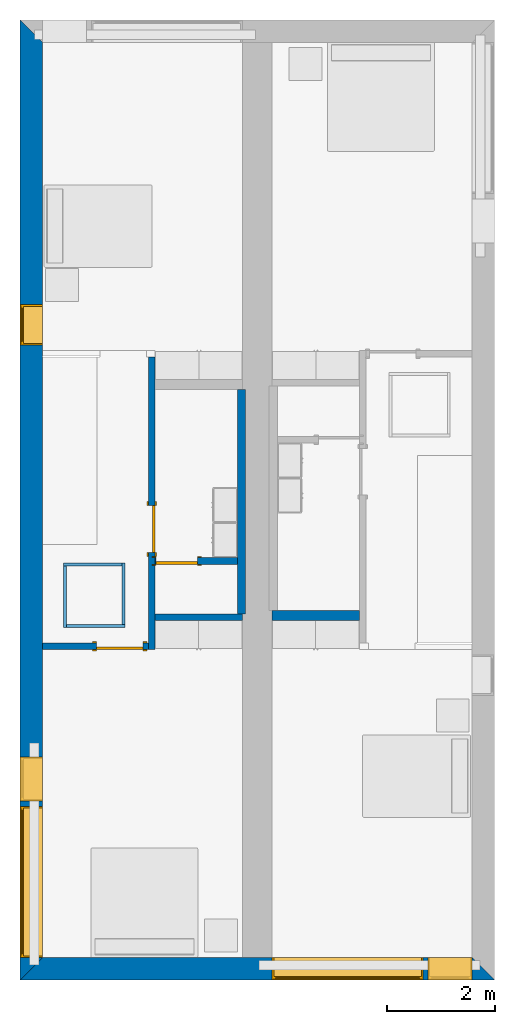
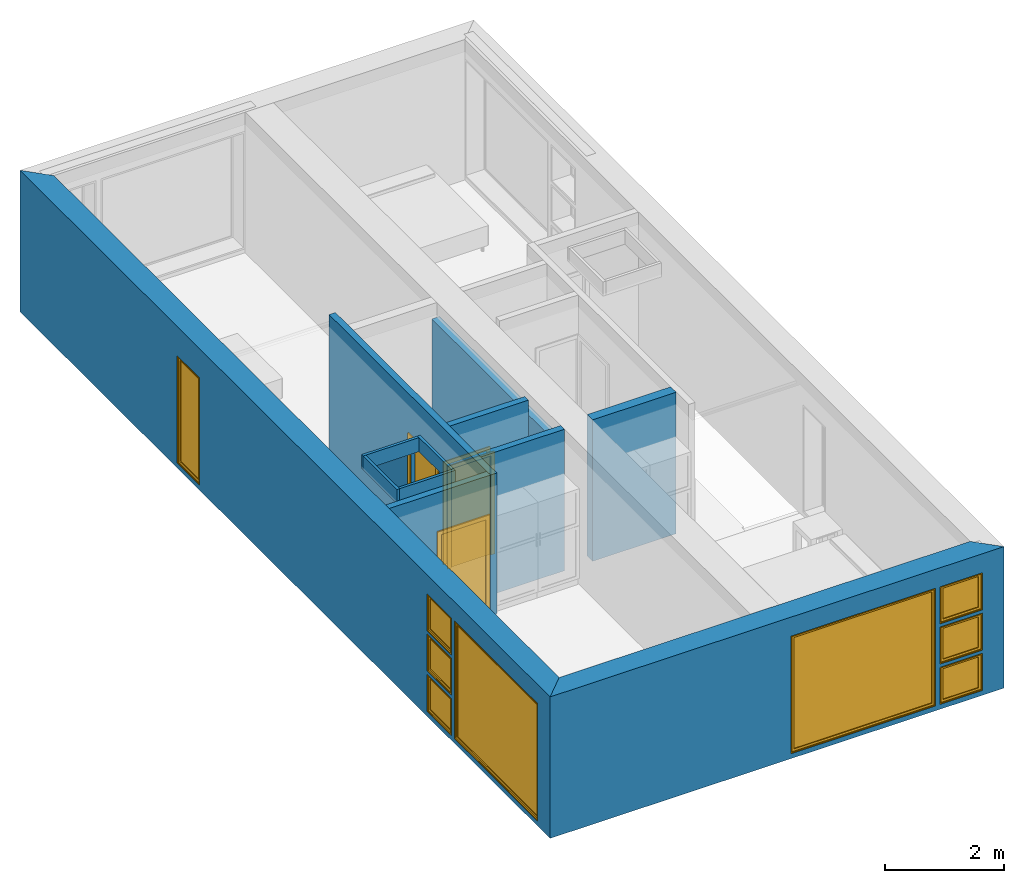
# One storey, part 2 of 12: 12 walls, 9 windows, 3 doors, 12 openings.
"""IFC2X3 building model written with IfcOpenShell, lengths in metres."""

import ifcopenshell
import ifcopenshell.guid

model = None  # the IFC model being written
_history = None  # IfcOwnerHistory: only IFC2X3 demands one
_inside = {}  # id of a spatial element -> (the spatial element, [elements in it])
_under = {}  # id of a project, library or spatial element -> (it, [spatial elements below it])
_declared = {}  # id of a project -> (the project, [libraries it declares])
_typed = {}  # id of a type object -> (the type object, [elements of that type])
_made_of = {}  # id of a material, layer set ... -> (it, [elements and type objects made of it])


def new_model(schema):
    """Start an empty IFC model of exactly this schema.

    Asked for "IFC4X3", IfcOpenShell would pick the latest addendum, in which some entities
    have other attributes; the version numbers below select the first issue.
    IFC2X3 requires an IfcOwnerHistory on every rooted entity: one is made here for all.
    """
    global model, _history
    if schema == "IFC4X3":
        model = ifcopenshell.file(schema_version=(4, 3, 0, 0))
    else:
        model = ifcopenshell.file(schema=schema)
    _inside.clear()
    _under.clear()
    _declared.clear()
    _typed.clear()
    _made_of.clear()
    _history = None
    if model.schema == "IFC2X3":
        org = make("IfcOrganization", Name="unknown")
        user = make(
            "IfcPersonAndOrganization",
            ThePerson=make("IfcPerson", FamilyName="unknown"),
            TheOrganization=org,
        )
        app = make(
            "IfcApplication",
            ApplicationDeveloper=org,
            Version="unknown",
            ApplicationFullName="unknown",
            ApplicationIdentifier="unknown",
        )
        _history = make(
            "IfcOwnerHistory",
            OwningUser=user,
            OwningApplication=app,
            ChangeAction="ADDED",
            CreationDate=0,
        )
    return model


def make(cls, **values):
    """One entity of the class cls with the attributes given. An attribute that is None is left unset."""
    return model.create_entity(
        cls, **{name: value for name, value in values.items() if value is not None}
    )


def entity(cls, *values):
    """Any entity or typed value of the class cls, its attributes in the order of the schema. None: left unset."""
    e = model.create_entity(cls)
    for i, value in enumerate(values):
        if value is not None:
            e[i] = value
    return e


def rooted(cls, **values):
    """An entity with a GlobalId (a new one), such as an element, a storey or a relation."""
    return make(cls, GlobalId=ifcopenshell.guid.new(), OwnerHistory=_history, **values)


def si_unit(unit_type, name, prefix=None):
    """IfcSIUnit, for example si_unit("LENGTHUNIT", "METRE", prefix="MILLI")."""
    return make("IfcSIUnit", UnitType=unit_type, Prefix=prefix, Name=name)


def converted_unit(unit_type, name, factor, base, dimensions=None, offset=None):
    """IfcConversionBasedUnit, such as the inch: factor (a typed value) times the base unit."""
    return make(
        "IfcConversionBasedUnit"
        if offset is None
        else "IfcConversionBasedUnitWithOffset",
        ConversionOffset=offset,
        Dimensions=None
        if dimensions is None
        else entity("IfcDimensionalExponents", *dimensions),
        UnitType=unit_type,
        Name=name,
        ConversionFactor=make(
            "IfcMeasureWithUnit", ValueComponent=factor, UnitComponent=base
        ),
    )


def assignment(units):
    """IfcUnitAssignment: the units of a project."""
    return None if units is None else make("IfcUnitAssignment", Units=units)


def point(xyz):
    """IfcCartesianPoint."""
    return None if xyz is None else make("IfcCartesianPoint", Coordinates=xyz)


def direction(xyz):
    """IfcDirection."""
    return None if xyz is None else make("IfcDirection", DirectionRatios=xyz)


def frame(location, z_axis=None, x_axis=None):
    """IfcAxis2Placement3D, a coordinate frame: its origin and axes. An axis left out is left unset."""
    return make(
        "IfcAxis2Placement3D",
        Location=point(location),
        Axis=direction(z_axis),
        RefDirection=direction(x_axis),
    )


def frame_2d(location, x_axis=None):
    """IfcAxis2Placement2D, a coordinate frame in the plane: its origin and x axis."""
    return make(
        "IfcAxis2Placement2D", Location=point(location), RefDirection=direction(x_axis)
    )


def origin():
    """The frame at (0, 0, 0) with its axes left unset."""
    return frame((0.0, 0.0, 0.0))


def origin_2d_with_axis():
    """The frame at (0, 0) in the plane with the x axis (1, 0) written out."""
    return frame_2d((0.0, 0.0), x_axis=(1.0, 0.0))


def place(relative_to, where):
    """IfcLocalPlacement: puts the frame where relative to a parent placement (None: the world)."""
    return make(
        "IfcLocalPlacement", PlacementRelTo=relative_to, RelativePlacement=where
    )


def context(
    kind, dimensions, precision=None, world=None, true_north=None, identifier=None
):
    """IfcGeometricRepresentationContext, for example the 3D "Model" context."""
    return make(
        "IfcGeometricRepresentationContext",
        ContextIdentifier=identifier,
        ContextType=kind,
        CoordinateSpaceDimension=dimensions,
        Precision=precision,
        WorldCoordinateSystem=world,
        TrueNorth=true_north,
    )


def project(units=None, contexts=None):
    """IfcProject with its units and contexts."""
    return rooted(
        "IfcProject",
        Name="project",
        RepresentationContexts=contexts,
        UnitsInContext=assignment(units),
    )


def spatial(cls, under=None, at=None, **own):
    """A site, building, storey or space (cls), placed at a placement, below another one or the project."""
    s = rooted(cls, ObjectPlacement=at, **own)
    if under is not None:
        _under.setdefault(under.id(), (under, []))[1].append(s)
    return s


def polyline(points):
    """IfcPolyline through the points."""
    return make("IfcPolyline", Points=[point(p) for p in points])


def profile(cls, at=None, kind="AREA", **sizes):
    """A parametric profile (cls). Its sizes go by their IFC names, for example OverallWidth=200.0."""
    return make(cls, ProfileType=kind, Position=at, **sizes)


def rectangle(**sizes):
    """IfcRectangleProfileDef."""
    return profile("IfcRectangleProfileDef", **sizes)


def outline(outer, holes=None, kind="AREA"):
    """IfcArbitraryClosedProfileDef: a profile drawn as a closed curve; with holes, ...WithVoids."""
    if holes is None:
        return make("IfcArbitraryClosedProfileDef", ProfileType=kind, OuterCurve=outer)
    return make(
        "IfcArbitraryProfileDefWithVoids",
        ProfileType=kind,
        OuterCurve=outer,
        InnerCurves=holes,
    )


def extrude(swept, where, along, depth):
    """IfcExtrudedAreaSolid: the profile swept, set in the frame where, extruded along a direction by depth."""
    return make(
        "IfcExtrudedAreaSolid",
        SweptArea=swept,
        Position=where,
        ExtrudedDirection=direction(along),
        Depth=depth,
    )


def shape(context_of_items, identifier, shape_type, items):
    """IfcShapeRepresentation: the items that make up one representation, for example the "Body"."""
    return make(
        "IfcShapeRepresentation",
        ContextOfItems=context_of_items,
        RepresentationIdentifier=identifier,
        RepresentationType=shape_type,
        Items=items,
    )


def source(mapping_origin, context_of_items, identifier, shape_type, items):
    """IfcRepresentationMap: a shape defined once, which mapped items show again and again."""
    return make(
        "IfcRepresentationMap",
        MappingOrigin=mapping_origin,
        MappedRepresentation=shape(context_of_items, identifier, shape_type, items),
    )


def transform(
    local_origin,
    x_axis=None,
    y_axis=None,
    z_axis=None,
    scale=None,
    scale2=None,
    scale3=None,
    uniform=True,
):
    """IfcCartesianTransformationOperator3D, or its non-uniform kind. x_axis, y_axis, z_axis: its Axis1, 2, 3."""
    if uniform:
        return make(
            "IfcCartesianTransformationOperator3D",
            Axis1=direction(x_axis),
            Axis2=direction(y_axis),
            LocalOrigin=point(local_origin),
            Scale=scale,
            Axis3=direction(z_axis),
        )
    return make(
        "IfcCartesianTransformationOperator3DnonUniform",
        Axis1=direction(x_axis),
        Axis2=direction(y_axis),
        LocalOrigin=point(local_origin),
        Scale=scale,
        Axis3=direction(z_axis),
        Scale2=scale2,
        Scale3=scale3,
    )


def mapped(mapping_source, mapping_target):
    """IfcMappedItem: shows the shape of a source again, moved by a transform."""
    return make(
        "IfcMappedItem", MappingSource=mapping_source, MappingTarget=mapping_target
    )


def material(Name=None, Category=None):
    """IfcMaterial."""
    return make("IfcMaterial", Name=Name, Category=Category)


def layer(
    of_material, thickness, ventilated=None, Name=None, Category=None, Priority=None
):
    """IfcMaterialLayer: one layer of a wall or slab, of a material (None: an air gap)."""
    return make(
        "IfcMaterialLayer",
        Material=of_material,
        LayerThickness=thickness,
        IsVentilated=ventilated,
        Name=Name,
        Category=Category,
        Priority=Priority,
    )


def layer_set(layers, Name=None):
    """IfcMaterialLayerSet."""
    return make("IfcMaterialLayerSet", MaterialLayers=layers, LayerSetName=Name)


def layer_usage(for_layer_set, set_direction, sense, offset, extent=None):
    """IfcMaterialLayerSetUsage: how a layer set lies in its element."""
    return make(
        "IfcMaterialLayerSetUsage",
        ForLayerSet=for_layer_set,
        LayerSetDirection=set_direction,
        DirectionSense=sense,
        OffsetFromReferenceLine=offset,
        ReferenceExtent=extent,
    )


def made_of(thing, what):
    """Note that an element or type object is made of a material, layer set ...; save() writes the relation."""
    if what is not None:
        _made_of.setdefault(what.id(), (what, []))[1].append(thing)
    return thing


def type_object(cls, material=None, **own):
    """A type object (cls), such as IfcWallType, which elements share."""
    return made_of(rooted(cls, **own), material)


def type_shapes(of_type, sources):
    """Give a type object the sources (RepresentationMaps) that its elements show as mapped items."""
    of_type.RepresentationMaps = sources


def element(
    cls,
    number,
    at=None,
    inside=None,
    cuts=None,
    type_object=None,
    material=None,
    context=None,
    identifier="Body",
    shape_type=None,
    held_by="IfcProductDefinitionShape",
    body=None,
    shapes=None,
    **own,
):
    """One element of the class cls, such as IfcWall. Its Tag is "e" and its number.

    at: its placement. inside: the storey or other place that contains it. cuts: it is an
    opening in that element (IfcRelVoidsElement). A single representation is given by context,
    identifier, shape_type and body (its items); several are given by shapes. held_by: the class
    of the entity that holds the representations. save() writes the other relations.
    """
    e = rooted(cls, Tag="e%d" % number, ObjectPlacement=at, **own)
    if body is not None:
        shapes = [shape(context, identifier, shape_type, body)]
    if shapes is not None:
        e.Representation = make(held_by, Representations=shapes)
    if inside is not None:
        _inside.setdefault(inside.id(), (inside, []))[1].append(e)
    if cuts is not None:
        rooted(
            "IfcRelVoidsElement", RelatingBuildingElement=cuts, RelatedOpeningElement=e
        )
    if type_object is not None:
        _typed.setdefault(type_object.id(), (type_object, []))[1].append(e)
    return made_of(e, material)


def fill(opening, filler):
    """IfcRelFillsElement: the door or window that sits in an opening."""
    return rooted(
        "IfcRelFillsElement",
        RelatingOpeningElement=opening,
        RelatedBuildingElement=filler,
    )


def aggregate(whole, parts):
    """IfcRelAggregates: a whole, such as a stair, and the parts it consists of."""
    return rooted("IfcRelAggregates", RelatingObject=whole, RelatedObjects=parts)


def save(model, path):
    """Write the relations noted so far, then the file.

    IfcRelAggregates (storeys below a building ...), IfcRelContainedInSpatialStructure (elements
    in a storey), IfcRelDefinesByType, IfcRelAssociatesMaterial and IfcRelDeclares: one each for
    every whole, place, type object, material and project.
    """
    for whole, parts in _under.values():
        aggregate(whole, parts)
    for where, things in _inside.values():
        rooted(
            "IfcRelContainedInSpatialStructure",
            RelatedElements=things,
            RelatingStructure=where,
        )
    for kind, things in _typed.values():
        rooted("IfcRelDefinesByType", RelatedObjects=things, RelatingType=kind)
    for what, things in _made_of.values():
        rooted("IfcRelAssociatesMaterial", RelatedObjects=things, RelatingMaterial=what)
    for by, libraries in _declared.values():
        rooted("IfcRelDeclares", RelatingContext=by, RelatedDefinitions=libraries)
    model.write(path)


model = new_model("IFC2X3")

# Units and contexts
model_context = context("Model", 3, precision=1e-09, world=origin())
plan_context = context("Plan", 3, precision=1e-09, world=origin())
ifc_project = project(units=[si_unit("LENGTHUNIT", "METRE"), si_unit("AREAUNIT", "SQUARE_METRE"), si_unit("VOLUMEUNIT", "CUBIC_METRE"), converted_unit("PLANEANGLEUNIT", "DEGREE", entity("IfcRatioMeasure", 0.0174532925199433), si_unit("PLANEANGLEUNIT", "RADIAN"), dimensions=[0, 0, 0, 0, 0, 0, 0]), si_unit("TIMEUNIT", "SECOND")], contexts=[model_context, plan_context])

# Site, building, storey
site_placement = place(None, origin())
site = spatial("IfcSite", under=ifc_project, at=site_placement, CompositionType="ELEMENT")
building_placement = place(site_placement, origin())
building = spatial("IfcBuilding", under=site, at=building_placement, CompositionType="ELEMENT")
storey_placement = place(building_placement, frame((0.0, 0.0, 3.10000000000038)))
storey = spatial("IfcBuildingStorey", under=building, at=storey_placement, Name="Level 2", CompositionType="ELEMENT", Elevation=3.10000000000038)

# Wall, openings, windows
ifc_material_1 = material(Name="Masonry - Brick")
ifc_layer_1 = layer(ifc_material_1, 0.092)
ifc_material_2 = material(Name="Misc. Air Layers - Air Space")
ifc_layer_2 = layer(ifc_material_2, 0.025)
ifc_material_3 = material(Name="Insulation / Thermal Barriers - Rigid insulation")
ifc_layer_3 = layer(ifc_material_3, 0.05)
ifc_material_4 = material(Name="Masonry - Concrete Block")
ifc_layer_4 = layer(ifc_material_4, 0.193)
ifc_material_5 = material(Name="Metal - Stud Layer")
ifc_layer_5 = layer(ifc_material_5, 0.041)
ifc_material_6 = material(Name="Plasterboard")
ifc_layer_6 = layer(ifc_material_6, 0.016)
ifc_layer_set_1 = layer_set([ifc_layer_1, ifc_layer_2, ifc_layer_3, ifc_layer_4, ifc_layer_5, ifc_layer_6], Name="Basic Wall:Exterior - Brick on Block")
ifc_layer_usage_1 = layer_usage(ifc_layer_set_1, "AXIS2", "NEGATIVE", 0.2085)
wall_1_placement = place(storey_placement, frame((8.79999999999997, -17.5915, 0.0), z_axis=(0.0, 0.0, 1.0), x_axis=(-1.0, 0.0, 0.0)))
wall_1 = element("IfcWallStandardCase", 1, at=wall_1_placement, inside=storey, material=ifc_layer_usage_1, Name="Basic Wall:Exterior - Brick on Block", ObjectType="Basic Wall:Exterior - Brick on Block", context=model_context, shape_type="SweptSolid", body=[
    extrude(outline(polyline([(8.38299999999997, -0.208499999999999), (8.79999999999997, 0.2085), (0.0, 0.2085), (0.417000000000003, -0.208500000000001), (4.125, -0.2085), (4.675, -0.2085), (8.38299999999997, -0.208499999999999)])), origin(), (0.0, 0.0, 1.0), 2.90000000000001),
])
opening_1_placement = place(wall_1_placement, frame((1.325, -0.208499999999998, 0.099999999999823)))
opening_1 = element("IfcOpeningElement", 2, at=opening_1_placement, cuts=wall_1, ObjectType="Opening", context=model_context, shape_type="SweptSolid", body=[
    extrude(rectangle(XDim=2.41, YDim=2.8, at=frame_2d((1.205, 1.4), x_axis=(1.0, 0.0))), frame((0.0, 0.0, 0.0), z_axis=(0.0, 1.0, 0.0), x_axis=(0.0, 0.0, 1.0)), (0.0, 0.0, 1.0), 0.417),
])
opening_2_placement = place(wall_1_placement, frame((0.417, -0.208499999999999, 0.0999999999998235)))
opening_2 = element("IfcOpeningElement", 3, at=opening_2_placement, cuts=wall_1, ObjectType="Opening", context=model_context, shape_type="SweptSolid", body=[
    extrude(rectangle(XDim=0.758999999999998, YDim=0.819, at=frame_2d((0.379499999999999, 0.4095), x_axis=(1.0, 0.0))), frame((0.0, 0.0, 0.0), z_axis=(0.0, 1.0, 0.0), x_axis=(0.0, 0.0, 1.0)), (0.0, 0.0, 1.0), 0.417),
])
opening_3_placement = place(wall_1_placement, frame((0.417000000000017, -0.2085, 0.925499999999818)))
opening_3 = element("IfcOpeningElement", 4, at=opening_3_placement, cuts=wall_1, ObjectType="Opening", context=model_context, shape_type="SweptSolid", body=[
    extrude(rectangle(XDim=0.759000000000001, YDim=0.819, at=frame_2d((0.3795, 0.4095), x_axis=(-1.0, 0.0))), frame((0.0, 0.0, 0.0), z_axis=(0.0, 1.0, 0.0), x_axis=(0.0, 0.0, 1.0)), (0.0, 0.0, 1.0), 0.417),
])
opening_4_placement = place(wall_1_placement, frame((0.417, -0.208499999999999, 1.75099999999982)))
opening_4 = element("IfcOpeningElement", 5, at=opening_4_placement, cuts=wall_1, ObjectType="Opening", context=model_context, shape_type="SweptSolid", body=[
    extrude(rectangle(XDim=0.758999999999998, YDim=0.819, at=frame_2d((0.379499999999999, 0.4095), x_axis=(1.0, 0.0))), frame((0.0, 0.0, 0.0), z_axis=(0.0, 1.0, 0.0), x_axis=(0.0, 0.0, 1.0)), (0.0, 0.0, 1.0), 0.417),
])
window_style_1 = type_object("IfcWindowStyle", Name="2800mm x 2410mm", ConstructionType="NOTDEFINED", OperationType="NOTDEFINED", ParameterTakesPrecedence=False, Sizeable=False)
shared_shape_1 = source(origin(), model_context, "Body", "SweptSolid", [
    extrude(rectangle(XDim=0.012, YDim=2.674, at=origin_2d_with_axis()), frame((1.40000000000001, 0.375999999999996, 0.0629999999999851), z_axis=(0.0, 0.0, 1.0), x_axis=(0.0, -1.0, 0.0)), (0.0, 0.0, 1.0), 2.28400000000001),
    extrude(outline(polyline([(-1.381, -1.186), (1.381, -1.186), (1.381, 1.186), (-1.381, 1.186), (-1.381, -1.186)]), holes=[polyline([(-1.337, -1.142), (-1.337, 1.142), (1.337, 1.142), (1.337, -1.142), (-1.337, -1.142)])]), frame((1.40000000000001, 0.353999999999968, 1.20499999999999), z_axis=(0.0, 1.0, 0.0), x_axis=(1.0, 0.0, 0.0)), (0.0, 0.0, 1.0), 0.0440000000000274),
    extrude(outline(polyline([(-1.4, -1.205), (1.4, -1.205), (1.4, 1.205), (-1.4, 1.205), (-1.4, -1.205)]), holes=[polyline([(-1.381, -1.18599999999998), (-1.381, 1.18600000000002), (1.381, 1.18600000000002), (1.381, -1.18599999999998), (-1.381, -1.18599999999998)])]), frame((1.40000000000001, 0.353999999999968, 1.20500000000001), z_axis=(0.0, 1.0, 0.0), x_axis=(1.0, 0.0, 0.0)), (0.0, 0.0, 1.0), 0.0630000000000274),
    extrude(outline(polyline([(-1.4, -1.20499999999999), (1.4, -1.20499999999999), (1.4, 1.20499999999999), (-1.4, 1.20499999999999), (-1.4, -1.20499999999999)]), holes=[polyline([(-1.368, -1.17299999999998), (-1.368, 1.17300000000002), (1.368, 1.17300000000002), (1.368, -1.17299999999998), (-1.368, -1.17299999999998)])]), frame((1.40000000000001, 0.0, 1.20500000000001), z_axis=(0.0, 1.0, 0.0), x_axis=(1.0, 0.0, 0.0)), (0.0, 0.0, 1.0), 0.353999999999973),
])
type_shapes(window_style_1, [shared_shape_1])
window_1_placement = place(opening_1_placement, origin())
window_1 = element("IfcWindow", 6, at=window_1_placement, inside=storey, type_object=window_style_1, ObjectType="2800mm x 2410mm", OverallHeight=2.41, OverallWidth=2.8, context=model_context, shape_type="MappedRepresentation", body=[
    mapped(shared_shape_1, transform((0.0, 0.0, 0.0), scale=1.0)),
])
fill(opening_1, window_1)
window_style_2 = type_object("IfcWindowStyle", Name="819mm x 759mm", ConstructionType="NOTDEFINED", OperationType="NOTDEFINED", ParameterTakesPrecedence=False, Sizeable=False)
shared_shape_2 = source(origin(), model_context, "Body", "SweptSolid", [
    extrude(rectangle(XDim=0.012, YDim=0.692999999999997, at=origin_2d_with_axis()), frame((0.409500000000007, 0.375999999999999, 0.0629999999999851), z_axis=(0.0, 0.0, 1.0), x_axis=(0.0, -1.0, 0.0)), (0.0, 0.0, 1.0), 0.633000000000007),
    extrude(outline(polyline([(-0.3905, -0.360500000000003), (0.3905, -0.360500000000003), (0.3905, 0.360500000000003), (-0.3905, 0.360500000000003), (-0.3905, -0.360500000000003)]), holes=[polyline([(-0.3465, -0.316500000000003), (-0.3465, 0.316500000000004), (0.346499999999997, 0.316500000000004), (0.346499999999997, -0.316500000000003), (-0.3465, -0.316500000000003)])]), frame((0.409500000000008, 0.353999999999971, 0.379499999999989), z_axis=(0.0, 1.0, 0.0), x_axis=(1.0, 0.0, 0.0)), (0.0, 0.0, 1.0), 0.0440000000000274),
    extrude(outline(polyline([(-0.4095, -0.379499999999997), (0.4095, -0.379499999999997), (0.4095, 0.379499999999997), (-0.4095, 0.379499999999997), (-0.4095, -0.379499999999997)]), holes=[polyline([(-0.390500000000001, -0.360499999999982), (-0.390500000000001, 0.360500000000023), (0.390499999999999, 0.360500000000023), (0.390499999999999, -0.360499999999982), (-0.390500000000001, -0.360499999999982)])]), frame((0.409500000000009, 0.353999999999971, 0.37950000000001), z_axis=(0.0, 1.0, 0.0), x_axis=(1.0, 0.0, 0.0)), (0.0, 0.0, 1.0), 0.0630000000000274),
    extrude(outline(polyline([(-0.4095, -0.379499999999997), (0.4095, -0.379499999999997), (0.4095, 0.379499999999997), (-0.4095, 0.379499999999997), (-0.4095, -0.379499999999997)]), holes=[polyline([(-0.3775, -0.347499999999983), (-0.3775, 0.347500000000021), (0.3775, 0.347500000000021), (0.3775, -0.347499999999983), (-0.3775, -0.347499999999983)])]), frame((0.40950000000001, 0.0, 0.379500000000009), z_axis=(0.0, 1.0, 0.0), x_axis=(1.0, 0.0, 0.0)), (0.0, 0.0, 1.0), 0.353999999999973),
])
type_shapes(window_style_2, [shared_shape_2])
window_2_placement = place(opening_2_placement, origin())
window_2 = element("IfcWindow", 7, at=window_2_placement, inside=storey, type_object=window_style_2, ObjectType="819mm x 759mm", OverallHeight=0.758999999999998, OverallWidth=0.819, context=model_context, shape_type="MappedRepresentation", body=[
    mapped(shared_shape_2, transform((0.0, 0.0, 0.0), scale=1.0)),
])
fill(opening_2, window_2)
window_3_placement = place(opening_4_placement, origin())
window_3 = element("IfcWindow", 8, at=window_3_placement, inside=storey, type_object=window_style_2, ObjectType="819mm x 759mm", OverallHeight=0.758999999999998, OverallWidth=0.819, context=model_context, shape_type="MappedRepresentation", body=[
    mapped(shared_shape_2, transform((0.0, 0.0, 0.0), scale=1.0)),
])
fill(opening_4, window_3)
window_style_3 = type_object("IfcWindowStyle", Name="819mm x 759mm", ConstructionType="NOTDEFINED", OperationType="NOTDEFINED", ParameterTakesPrecedence=False, Sizeable=False)
shared_shape_3 = source(origin(), model_context, "Body", "SweptSolid", [
    extrude(rectangle(XDim=0.0127, YDim=0.691999999999998, at=origin_2d_with_axis()), frame((0.4095, 0.375775, 0.063500000000004), z_axis=(0.0, 0.0, 1.0), x_axis=(0.0, 1.0, 0.0)), (0.0, 0.0, 1.0), 0.632000000000004),
    extrude(outline(polyline([(-0.390449999999999, -0.360450000000001), (0.390449999999999, -0.360450000000001), (0.390449999999999, 0.360450000000001), (-0.390449999999999, 0.360450000000001), (-0.390449999999999, -0.360450000000001)]), holes=[polyline([(-0.345999999999998, -0.316000000000002), (-0.345999999999998, 0.316000000000003), (0.346, 0.316000000000003), (0.346, -0.316000000000002), (-0.345999999999998, -0.316000000000002)])]), frame((0.409499999999999, 0.35355, 0.379500000000007), z_axis=(0.0, 1.0, 0.0), x_axis=(1.0, 0.0, 0.0)), (0.0, 0.0, 1.0), 0.04445),
    extrude(outline(polyline([(-0.409499999999999, -0.379500000000001), (0.409499999999999, -0.379500000000001), (0.409499999999999, 0.379500000000001), (-0.409499999999999, 0.379500000000001), (-0.409499999999999, -0.379500000000001)]), holes=[polyline([(-0.37775, -0.34775), (-0.37775, 0.347750000000001), (0.377749999999998, 0.347750000000001), (0.377749999999998, -0.34775), (-0.37775, -0.34775)])]), frame((0.409500000000001, 0.0, 0.379500000000008), z_axis=(0.0, 1.0, 0.0), x_axis=(1.0, 0.0, 0.0)), (0.0, 0.0, 1.0), 0.35355),
    extrude(outline(polyline([(-0.379500000000002, -0.409499999999999), (0.379500000000002, -0.409499999999999), (0.379500000000002, 0.409499999999999), (-0.379500000000002, 0.409499999999999), (-0.379500000000002, -0.409499999999999)]), holes=[polyline([(-0.360450000000002, -0.390449999999999), (-0.360450000000002, 0.39045), (0.360450000000002, 0.39045), (0.360450000000002, -0.390449999999999), (-0.360450000000002, -0.390449999999999)])]), frame((0.4095, 0.35355, 0.379500000000007), z_axis=(0.0, 1.0, 0.0), x_axis=(0.0, 0.0, -1.0)), (0.0, 0.0, 1.0), 0.06345),
])
type_shapes(window_style_3, [shared_shape_3])
window_4_placement = place(opening_3_placement, origin())
window_4 = element("IfcWindow", 9, at=window_4_placement, inside=storey, type_object=window_style_3, ObjectType="819mm x 759mm", OverallHeight=0.759000000000001, OverallWidth=0.819, context=model_context, shape_type="MappedRepresentation", body=[
    mapped(shared_shape_3, transform((0.0, 0.0, 0.0), scale=1.0)),
])
fill(opening_3, window_4)

ifc_layer_usage_2 = layer_usage(ifc_layer_set_1, "AXIS2", "NEGATIVE", 0.2085)
wall_2_placement = place(storey_placement, frame((0.208499999999999, -17.8, 0.0), z_axis=(0.0, 0.0, 1.0), x_axis=(0.0, 1.0, 0.0)))
wall_2 = element("IfcWallStandardCase", 10, at=wall_2_placement, inside=storey, material=ifc_layer_usage_2, Name="Basic Wall:Exterior - Brick on Block", ObjectType="Basic Wall:Exterior - Brick on Block", context=model_context, shape_type="SweptSolid", body=[
    extrude(outline(polyline([(17.383, -0.2085), (17.8, 0.2085), (0.0, 0.2085), (0.417, -0.2085), (6.12599999999998, -0.2085), (6.24999999999998, -0.2085), (17.383, -0.2085)])), origin(), (0.0, 0.0, 1.0), 2.90000000000001),
])
opening_5_placement = place(wall_2_placement, frame((0.416999999999998, -0.208499999999996, 0.0999999999998186)))
opening_5 = element("IfcOpeningElement", 11, at=opening_5_placement, cuts=wall_2, ObjectType="Opening", context=model_context, shape_type="SweptSolid", body=[
    extrude(rectangle(XDim=2.41, YDim=2.8, at=frame_2d((1.205, 1.4), x_axis=(1.0, 0.0))), frame((0.0, 0.0, 0.0), z_axis=(0.0, 1.0, 0.0), x_axis=(0.0, 0.0, 1.0)), (0.0, 0.0, 1.0), 0.417),
])
opening_6_placement = place(wall_2_placement, frame((3.317, -0.208499999999999, 1.75099999999982)))
opening_6 = element("IfcOpeningElement", 12, at=opening_6_placement, cuts=wall_2, ObjectType="Opening", context=model_context, shape_type="SweptSolid", body=[
    extrude(rectangle(XDim=0.758999999999998, YDim=0.819, at=frame_2d((0.379499999999999, 0.4095), x_axis=(1.0, 0.0))), frame((0.0, 0.0, 0.0), z_axis=(0.0, 1.0, 0.0), x_axis=(0.0, 0.0, 1.0)), (0.0, 0.0, 1.0), 0.417),
])
opening_7_placement = place(wall_2_placement, frame((3.317, -0.208499999999999, 0.0999999999998186)))
opening_7 = element("IfcOpeningElement", 13, at=opening_7_placement, cuts=wall_2, ObjectType="Opening", context=model_context, shape_type="SweptSolid", body=[
    extrude(rectangle(XDim=0.758999999999998, YDim=0.819, at=frame_2d((0.379499999999999, 0.4095), x_axis=(1.0, 0.0))), frame((0.0, 0.0, 0.0), z_axis=(0.0, 1.0, 0.0), x_axis=(0.0, 0.0, 1.0)), (0.0, 0.0, 1.0), 0.417),
])
opening_8_placement = place(wall_2_placement, frame((3.31700000000001, -0.2085, 0.925499999999818)))
opening_8 = element("IfcOpeningElement", 14, at=opening_8_placement, cuts=wall_2, ObjectType="Opening", context=model_context, shape_type="SweptSolid", body=[
    extrude(rectangle(XDim=0.759000000000001, YDim=0.819, at=frame_2d((0.3795, 0.4095), x_axis=(-1.0, 0.0))), frame((0.0, 0.0, 0.0), z_axis=(0.0, 1.0, 0.0), x_axis=(0.0, 0.0, 1.0)), (0.0, 0.0, 1.0), 0.417),
])
opening_9_placement = place(wall_2_placement, frame((11.774, -0.2085, 0.0999999999998186)))
opening_9 = element("IfcOpeningElement", 15, at=opening_9_placement, cuts=wall_2, ObjectType="Opening", context=model_context, shape_type="SweptSolid", body=[
    extrude(rectangle(XDim=2.2, YDim=0.75, at=frame_2d((1.1, 0.374999999999999), x_axis=(1.0, 0.0))), frame((0.0, 0.0, 0.0), z_axis=(0.0, 1.0, 0.0), x_axis=(0.0, 0.0, 1.0)), (0.0, 0.0, 1.0), 0.417),
])
window_style_4 = type_object("IfcWindowStyle", Name="750mm x 2200mm", ConstructionType="NOTDEFINED", OperationType="NOTDEFINED", ParameterTakesPrecedence=False, Sizeable=False)
shared_shape_4 = source(origin(), model_context, "Body", "SweptSolid", [
    extrude(rectangle(XDim=0.012, YDim=0.623999999999997, at=origin_2d_with_axis()), frame((0.375000000000007, 0.375999999999999, 0.0629999999999851), z_axis=(0.0, 0.0, 1.0), x_axis=(0.0, -1.0, 0.0)), (0.0, 0.0, 1.0), 2.07400000000001),
    extrude(outline(polyline([(-0.356, -1.081), (0.356, -1.081), (0.356, 1.081), (-0.356, 1.081), (-0.356, -1.081)]), holes=[polyline([(-0.312, -1.037), (-0.312, 1.037), (0.311999999999998, 1.037), (0.311999999999998, -1.037), (-0.312, -1.037)])]), frame((0.375000000000008, 0.353999999999972, 1.09999999999999), z_axis=(0.0, 1.0, 0.0), x_axis=(1.0, 0.0, 0.0)), (0.0, 0.0, 1.0), 0.0440000000000274),
    extrude(outline(polyline([(-0.375, -1.1), (0.375, -1.1), (0.375, 1.1), (-0.375, 1.1), (-0.375, -1.1)]), holes=[polyline([(-0.356000000000001, -1.08099999999998), (-0.356000000000001, 1.08100000000002), (0.355999999999998, 1.08100000000002), (0.355999999999999, -1.08099999999998), (-0.356000000000001, -1.08099999999998)])]), frame((0.375000000000009, 0.353999999999972, 1.10000000000001), z_axis=(0.0, 1.0, 0.0), x_axis=(1.0, 0.0, 0.0)), (0.0, 0.0, 1.0), 0.0630000000000274),
    extrude(outline(polyline([(-0.375, -1.1), (0.375, -1.1), (0.375, 1.1), (-0.375, 1.1), (-0.375, -1.1)]), holes=[polyline([(-0.343, -1.06799999999998), (-0.343, 1.06800000000002), (0.343, 1.06800000000002), (0.343, -1.06799999999998), (-0.343, -1.06799999999998)])]), frame((0.37500000000001, 0.0, 1.10000000000001), z_axis=(0.0, 1.0, 0.0), x_axis=(1.0, 0.0, 0.0)), (0.0, 0.0, 1.0), 0.353999999999973),
])
type_shapes(window_style_4, [shared_shape_4])
window_5_placement = place(opening_9_placement, origin())
window_5 = element("IfcWindow", 16, at=window_5_placement, inside=storey, type_object=window_style_4, ObjectType="750mm x 2200mm", OverallHeight=2.2, OverallWidth=0.75, context=model_context, shape_type="MappedRepresentation", body=[
    mapped(shared_shape_4, transform((0.0, 0.0, 0.0), scale=1.0)),
])
fill(opening_9, window_5)
window_6_placement = place(opening_5_placement, origin())
window_6 = element("IfcWindow", 17, at=window_6_placement, inside=storey, type_object=window_style_1, ObjectType="2800mm x 2410mm", OverallHeight=2.41, OverallWidth=2.8, context=model_context, shape_type="MappedRepresentation", body=[
    mapped(shared_shape_1, transform((0.0, 0.0, 0.0), scale=1.0)),
])
fill(opening_5, window_6)
window_7_placement = place(opening_6_placement, origin())
window_7 = element("IfcWindow", 18, at=window_7_placement, inside=storey, type_object=window_style_2, ObjectType="819mm x 759mm", OverallHeight=0.758999999999998, OverallWidth=0.819, context=model_context, shape_type="MappedRepresentation", body=[
    mapped(shared_shape_2, transform((0.0, 0.0, 0.0), scale=1.0)),
])
fill(opening_6, window_7)
window_8_placement = place(opening_7_placement, origin())
window_8 = element("IfcWindow", 19, at=window_8_placement, inside=storey, type_object=window_style_2, ObjectType="819mm x 759mm", OverallHeight=0.758999999999999, OverallWidth=0.819, context=model_context, shape_type="MappedRepresentation", body=[
    mapped(shared_shape_2, transform((0.0, 0.0, 0.0), scale=1.0)),
])
fill(opening_7, window_8)
window_9_placement = place(opening_8_placement, origin())
window_9 = element("IfcWindow", 20, at=window_9_placement, inside=storey, type_object=window_style_3, ObjectType="819mm x 759mm", OverallHeight=0.759000000000001, OverallWidth=0.819, context=model_context, shape_type="MappedRepresentation", body=[
    mapped(shared_shape_3, transform((0.0, 0.0, 0.0), scale=1.0)),
])
fill(opening_8, window_9)

# Wall, opening, door
ifc_layer_7 = layer(ifc_material_6, 0.016)
ifc_layer_8 = layer(ifc_material_5, 0.092)
ifc_layer_9 = layer(ifc_material_6, 0.016)
ifc_layer_set_2 = layer_set([ifc_layer_7, ifc_layer_8, ifc_layer_9], Name="Basic Wall:Interior - Partition (92mm Stud)")
ifc_layer_usage_3 = layer_usage(ifc_layer_set_2, "AXIS2", "NEGATIVE", 0.062)
wall_3_placement = place(storey_placement, frame((2.444, -6.25000000000001, 0.0), z_axis=(0.0, 0.0, 1.0), x_axis=(0.0, -1.0, 0.0)))
wall_3 = element("IfcWallStandardCase", 21, at=wall_3_placement, inside=storey, material=ifc_layer_usage_3, Name="Basic Wall:Interior - Partition (92mm Stud)", ObjectType="Basic Wall:Interior - Partition (92mm Stud)", context=model_context, shape_type="SweptSolid", body=[
    extrude(rectangle(XDim=5.424, YDim=0.124, at=frame_2d((2.712, 0.0), x_axis=(-1.0, 0.0))), origin(), (0.0, 0.0, 1.0), 2.90000000000001),
])
opening_10_placement = place(wall_3_placement, frame((2.75605117851058, -0.0620000000000057, 0.0)))
opening_10 = element("IfcOpeningElement", 22, at=opening_10_placement, cuts=wall_3, Name="M_Single-Flush:0864 x 2032mm:0864 x 2032mm:1", ObjectType="Opening", context=model_context, shape_type="SweptSolid", body=[
    extrude(rectangle(XDim=0.863999999999999, YDim=2.032, at=frame_2d((1.016, 0.431999999999999), x_axis=(0.0, 1.0))), frame((0.0, 0.0, 0.0), z_axis=(0.0, 1.0, 0.0), x_axis=(0.0, 0.0, 1.0)), (0.0, 0.0, 1.0), 0.124),
])
door_style_1 = type_object("IfcDoorStyle", Name="0864 x 2032mm", ConstructionType="NOTDEFINED", OperationType="SINGLE_SWING_RIGHT", ParameterTakesPrecedence=False, Sizeable=False)
shared_shape_5 = source(origin(), model_context, "Body", "SweptSolid", [
    extrude(outline(polyline([(-0.508, -1.073), (0.508, -1.073), (0.508, 1.035), (0.432, 1.035), (0.432, -0.997000000000002), (-0.432, -0.997000000000002), (-0.432, 1.035), (-0.508, 1.035), (-0.508, -1.073)])), frame((0.432000000000001, 0.123999999999999, 1.035), z_axis=(0.0, 1.0, 0.0), x_axis=(1.0, 0.0, 0.0)), (0.0, 0.0, 1.0), 0.0249999999999944),
    extrude(outline(polyline([(-1.073, -0.507999999999997), (1.035, -0.507999999999997), (1.035, -0.432000000000007), (-0.997, -0.432000000000007), (-0.997, 0.432000000000002), (1.035, 0.432000000000002), (1.035, 0.508000000000003), (-1.073, 0.508000000000003), (-1.073, -0.507999999999997)])), frame((0.432000000000003, -0.0250000000000064, 1.035), z_axis=(0.0, 1.0, 0.0), x_axis=(0.0, 0.0, -1.0)), (0.0, 0.0, 1.0), 0.0250000000000056),
    extrude(rectangle(XDim=0.051, YDim=0.864, at=origin_2d_with_axis()), frame((0.432, 0.0984999999999992, 0.0), z_axis=(0.0, 0.0, 1.0), x_axis=(0.0, 1.0, 0.0)), (0.0, 0.0, 1.0), 2.032),
])
type_shapes(door_style_1, [shared_shape_5])
door_1_placement = place(opening_10_placement, origin())
door_1 = element("IfcDoor", 23, at=door_1_placement, inside=storey, type_object=door_style_1, Name="M_Single-Flush:0864 x 2032mm:0864 x 2032mm", ObjectType="0864 x 2032mm", OverallHeight=2.032, OverallWidth=0.863999999999999, context=model_context, shape_type="MappedRepresentation", body=[
    mapped(shared_shape_5, transform((0.0, 0.0, 0.0), scale=1.0)),
])
fill(opening_10, door_1)

ifc_layer_usage_4 = layer_usage(ifc_layer_set_2, "AXIS2", "NEGATIVE", 0.062)
wall_4_placement = place(storey_placement, frame((2.38199999999999, -11.612, 0.0), z_axis=(0.0, 0.0, 1.0), x_axis=(-1.0, 0.0, 0.0)))
wall_4 = element("IfcWallStandardCase", 24, at=wall_4_placement, inside=storey, material=ifc_layer_usage_4, Name="Basic Wall:Interior - Partition (92mm Stud)", ObjectType="Basic Wall:Interior - Partition (92mm Stud)", context=model_context, shape_type="SweptSolid", body=[
    extrude(rectangle(XDim=1.96499999999999, YDim=0.124000000000002, at=frame_2d((0.982499999999996, 0.0), x_axis=(-1.0, 0.0))), origin(), (0.0, 0.0, 1.0), 2.90000000000001),
])
opening_11_placement = place(wall_4_placement, frame((0.0999999999999989, -0.0620000000000021, 0.0)))
opening_11 = element("IfcOpeningElement", 25, at=opening_11_placement, cuts=wall_4, Name="M_Single-Flush:0864 x 2032mm:0864 x 2032mm:1", ObjectType="Opening", context=model_context, shape_type="SweptSolid", body=[
    extrude(rectangle(XDim=0.863999999999999, YDim=2.032, at=frame_2d((1.016, 0.432), x_axis=(0.0, -1.0))), frame((0.0, 0.0, 0.0), z_axis=(0.0, 1.0, 0.0), x_axis=(0.0, 0.0, 1.0)), (0.0, 0.0, 1.0), 0.124),
])
door_style_2 = type_object("IfcDoorStyle", Name="0864 x 2032mm", ConstructionType="NOTDEFINED", OperationType="SINGLE_SWING_LEFT", ParameterTakesPrecedence=False, Sizeable=False)
shared_shape_6 = source(origin(), model_context, "Body", "SweptSolid", [
    extrude(outline(polyline([(-0.508, -1.073), (0.508, -1.073), (0.508, 1.035), (0.432, 1.035), (0.432, -0.997000000000002), (-0.432, -0.997000000000002), (-0.432, 1.035), (-0.508, 1.035), (-0.508, -1.073)])), frame((0.432, 0.148999999999988, 1.035), z_axis=(0.0, -1.0, 0.0), x_axis=(-1.0, 0.0, 0.0)), (0.0, 0.0, 1.0), 0.0249999999999944),
    extrude(outline(polyline([(-1.073, -0.507999999999997), (1.035, -0.507999999999997), (1.035, -0.432000000000007), (-0.997, -0.432000000000007), (-0.997, 0.432000000000002), (1.035, 0.432000000000002), (1.035, 0.508000000000003), (-1.073, 0.508000000000003), (-1.073, -0.507999999999997)])), frame((0.431999999999998, 0.0, 1.035), z_axis=(0.0, -1.0, 0.0), x_axis=(0.0, 0.0, -1.0)), (0.0, 0.0, 1.0), 0.0250000000000056),
    extrude(rectangle(XDim=0.864, YDim=0.051, at=origin_2d_with_axis()), frame((0.432, 0.0984999999999937, 0.0)), (0.0, 0.0, 1.0), 2.032),
])
type_shapes(door_style_2, [shared_shape_6])
door_2_placement = place(opening_11_placement, origin())
door_2 = element("IfcDoor", 26, at=door_2_placement, inside=storey, type_object=door_style_2, Name="M_Single-Flush:0864 x 2032mm:0864 x 2032mm", ObjectType="0864 x 2032mm", OverallHeight=2.032, OverallWidth=0.864, context=model_context, shape_type="MappedRepresentation", body=[
    mapped(shared_shape_6, transform((0.0, 0.0, 0.0), scale=1.0)),
])
fill(opening_11, door_2)

# Walls
ifc_layer_usage_5 = layer_usage(ifc_layer_set_2, "AXIS2", "NEGATIVE", 0.062)
wall_5_placement = place(storey_placement, frame((4.12499999999998, -11.072, 0.0), z_axis=(0.0, 0.0, 1.0), x_axis=(-1.0, 0.0, 0.0)))
element("IfcWallStandardCase", 27, at=wall_5_placement, inside=storey, material=ifc_layer_usage_5, Name="Basic Wall:Interior - Partition (92mm Stud)", ObjectType="Basic Wall:Interior - Partition (92mm Stud)", context=model_context, shape_type="SweptSolid", body=[
    extrude(rectangle(XDim=1.61899999999999, YDim=0.124000000000002, at=frame_2d((0.809499999999995, 0.0), x_axis=(-1.0, 0.0))), origin(), (0.0, 0.0, 1.0), 2.90000000000001),
])
ifc_layer_10 = layer(ifc_material_6, 0.016)
ifc_layer_11 = layer(ifc_material_5, 0.152)
ifc_layer_12 = layer(ifc_material_6, 0.016)
ifc_layer_set_3 = layer_set([ifc_layer_10, ifc_layer_11, ifc_layer_12], Name="Basic Wall:Interior - Plumbing (152mm Stud)")
ifc_layer_usage_6 = layer_usage(ifc_layer_set_3, "AXIS2", "NEGATIVE", 0.092)
wall_6_placement = place(storey_placement, frame((6.294, -11.042, 0.0), z_axis=(0.0, 0.0, 1.0), x_axis=(-1.0, 0.0, 0.0)))
element("IfcWallStandardCase", 28, at=wall_6_placement, inside=storey, material=ifc_layer_usage_6, Name="Basic Wall:Interior - Plumbing (152mm Stud)", ObjectType="Basic Wall:Interior - Plumbing (152mm Stud)", context=model_context, shape_type="SweptSolid", body=[
    extrude(rectangle(XDim=1.61900000000002, YDim=0.184000000000001, at=frame_2d((0.809500000000009, 0.0), x_axis=(-1.0, 0.0))), origin(), (0.0, 0.0, 1.0), 2.90000000000001),
])
ifc_layer_13 = layer(ifc_material_5, 0.136)
ifc_layer_14 = layer(ifc_material_6, 0.016)
ifc_layer_set_4 = layer_set([ifc_layer_13, ifc_layer_14], Name="Basic Wall:Interior - Furring (152 mm Stud)")
ifc_layer_usage_7 = layer_usage(ifc_layer_set_4, "AXIS2", "POSITIVE", -0.076)
wall_7_placement = place(storey_placement, frame((4.10599999999998, -11.01, 0.0), z_axis=(0.0, 0.0, 1.0), x_axis=(0.0, 1.0, 0.0)))
element("IfcWallStandardCase", 29, at=wall_7_placement, inside=storey, material=ifc_layer_usage_7, Name="Basic Wall:Interior - Furring (152 mm Stud)", ObjectType="Basic Wall:Interior - Furring (152 mm Stud)", context=model_context, shape_type="SweptSolid", body=[
    extrude(rectangle(XDim=4.16, YDim=0.152, at=frame_2d((2.08, 0.0), x_axis=(-1.0, 0.0))), origin(), (0.0, 0.0, 1.0), 2.59500000000001),
])

# Wall, opening, door
ifc_layer_usage_8 = layer_usage(ifc_layer_set_2, "AXIS2", "NEGATIVE", 0.062)
wall_8_placement = place(storey_placement, frame((4.02999999999998, -10.0320511785106, 0.0), z_axis=(0.0, 0.0, 1.0), x_axis=(-1.0, 0.0, 0.0)))
wall_8 = element("IfcWallStandardCase", 30, at=wall_8_placement, inside=storey, material=ifc_layer_usage_8, Name="Basic Wall:Interior - Partition (92mm Stud)", ObjectType="Basic Wall:Interior - Partition (92mm Stud)", context=model_context, shape_type="SweptSolid", body=[
    extrude(rectangle(XDim=1.52399999999999, YDim=0.124000000000002, at=frame_2d((0.761999999999995, 0.0), x_axis=(-1.0, 0.0))), origin(), (0.0, 0.0, 1.0), 2.90000000000001),
])
opening_12_placement = place(wall_8_placement, frame((0.741999999999986, -0.0619999999999989, 0.0)))
opening_12 = element("IfcOpeningElement", 31, at=opening_12_placement, cuts=wall_8, Name="M_Single-Flush:0762 x 2032mm:0762 x 2032mm:1", ObjectType="Opening", context=model_context, shape_type="SweptSolid", body=[
    extrude(rectangle(XDim=0.762, YDim=2.032, at=frame_2d((1.016, 0.381), x_axis=(0.0, 1.0))), frame((0.0, 0.0, 0.0), z_axis=(0.0, 1.0, 0.0), x_axis=(0.0, 0.0, 1.0)), (0.0, 0.0, 1.0), 0.124),
])
door_style_3 = type_object("IfcDoorStyle", Name="0762 x 2032mm", ConstructionType="NOTDEFINED", OperationType="SINGLE_SWING_RIGHT", ParameterTakesPrecedence=False, Sizeable=False)
shared_shape_7 = source(origin(), model_context, "Body", "SweptSolid", [
    extrude(outline(polyline([(-0.457, -1.073), (0.457, -1.073), (0.457, 1.035), (0.381, 1.035), (0.381, -0.997000000000002), (-0.381, -0.997000000000002), (-0.381, 1.035), (-0.457, 1.035), (-0.457, -1.073)])), frame((0.381000000000001, 0.123999999999999, 1.035), z_axis=(0.0, 1.0, 0.0), x_axis=(1.0, 0.0, 0.0)), (0.0, 0.0, 1.0), 0.0249999999999945),
    extrude(outline(polyline([(-1.073, -0.456999999999997), (1.035, -0.456999999999997), (1.035, -0.381000000000007), (-0.997, -0.381000000000007), (-0.997, 0.381000000000002), (1.035, 0.381000000000002), (1.035, 0.457000000000003), (-1.073, 0.457000000000003), (-1.073, -0.456999999999997)])), frame((0.381000000000003, -0.0250000000000063, 1.035), z_axis=(0.0, 1.0, 0.0), x_axis=(0.0, 0.0, -1.0)), (0.0, 0.0, 1.0), 0.0250000000000056),
    extrude(rectangle(XDim=0.051, YDim=0.762, at=origin_2d_with_axis()), frame((0.381000000000001, 0.0984999999999993, 0.0), z_axis=(0.0, 0.0, 1.0), x_axis=(0.0, 1.0, 0.0)), (0.0, 0.0, 1.0), 2.032),
])
type_shapes(door_style_3, [shared_shape_7])
door_3_placement = place(opening_12_placement, origin())
door_3 = element("IfcDoor", 32, at=door_3_placement, inside=storey, type_object=door_style_3, Name="M_Single-Flush:0762 x 2032mm:0762 x 2032mm", ObjectType="0762 x 2032mm", OverallHeight=2.032, OverallWidth=0.762, context=model_context, shape_type="MappedRepresentation", body=[
    mapped(shared_shape_7, transform((0.0, 0.0, 0.0), scale=1.0)),
])
fill(opening_12, door_3)

# Walls
ifc_layer_15 = layer(ifc_material_5, 0.038)
ifc_layer_16 = layer(ifc_material_6, 0.016)
ifc_layer_set_5 = layer_set([ifc_layer_15, ifc_layer_16], Name="Basic Wall:Interior - Furring (38 mm Stud)")
ifc_layer_usage_9 = layer_usage(ifc_layer_set_5, "AXIS2", "NEGATIVE", 0.027)
wall_9_placement = place(storey_placement, frame((0.807450000000026, -10.09745, 2.612)))
element("IfcWallStandardCase", 33, at=wall_9_placement, inside=storey, material=ifc_layer_usage_9, Name="Basic Wall:Interior - Furring (38 mm Stud)", ObjectType="Basic Wall:Interior - Furring (38 mm Stud)", context=model_context, shape_type="SweptSolid", body=[
    extrude(rectangle(XDim=1.0831, YDim=0.0540000000000007, at=frame_2d((0.54155, 0.0), x_axis=(-1.0, 0.0))), origin(), (0.0, 0.0, 1.0), 0.288000000000013),
])
ifc_layer_usage_10 = layer_usage(ifc_layer_set_5, "AXIS2", "NEGATIVE", 0.027)
wall_10_placement = place(storey_placement, frame((0.834450000000026, -11.25955, 2.612), z_axis=(0.0, 0.0, 1.0), x_axis=(0.0, 1.0, 0.0)))
element("IfcWallStandardCase", 34, at=wall_10_placement, inside=storey, material=ifc_layer_usage_10, Name="Basic Wall:Interior - Furring (38 mm Stud)", ObjectType="Basic Wall:Interior - Furring (38 mm Stud)", context=model_context, shape_type="SweptSolid", body=[
    extrude(rectangle(XDim=1.13509999999996, YDim=0.0539999999999999, at=frame_2d((0.567549999999978, 0.0), x_axis=(-1.0, 0.0))), origin(), (0.0, 0.0, 1.0), 0.288000000000013),
])
ifc_layer_usage_11 = layer_usage(ifc_layer_set_5, "AXIS2", "NEGATIVE", 0.027)
wall_11_placement = place(storey_placement, frame((1.94455000000003, -11.23255, 2.612), z_axis=(0.0, 0.0, 1.0), x_axis=(-1.0, 0.0, 0.0)))
element("IfcWallStandardCase", 35, at=wall_11_placement, inside=storey, material=ifc_layer_usage_11, Name="Basic Wall:Interior - Furring (38 mm Stud)", ObjectType="Basic Wall:Interior - Furring (38 mm Stud)", context=model_context, shape_type="SweptSolid", body=[
    extrude(rectangle(XDim=1.0831, YDim=0.0540000000000007, at=frame_2d((0.54155, 0.0), x_axis=(-1.0, 0.0))), origin(), (0.0, 0.0, 1.0), 0.288000000000013),
])
ifc_layer_usage_12 = layer_usage(ifc_layer_set_5, "AXIS2", "NEGATIVE", 0.027)
wall_12_placement = place(storey_placement, frame((1.91755000000002, -10.07045, 2.612), z_axis=(0.0, 0.0, 1.0), x_axis=(0.0, -1.0, 0.0)))
element("IfcWallStandardCase", 36, at=wall_12_placement, inside=storey, material=ifc_layer_usage_12, Name="Basic Wall:Interior - Furring (38 mm Stud)", ObjectType="Basic Wall:Interior - Furring (38 mm Stud)", context=model_context, shape_type="SweptSolid", body=[
    extrude(rectangle(XDim=1.13509999999996, YDim=0.0540000000000002, at=frame_2d((0.567549999999979, 0.0), x_axis=(-1.0, 0.0))), origin(), (0.0, 0.0, 1.0), 0.288000000000013),
])

save(model, "model.ifc")
